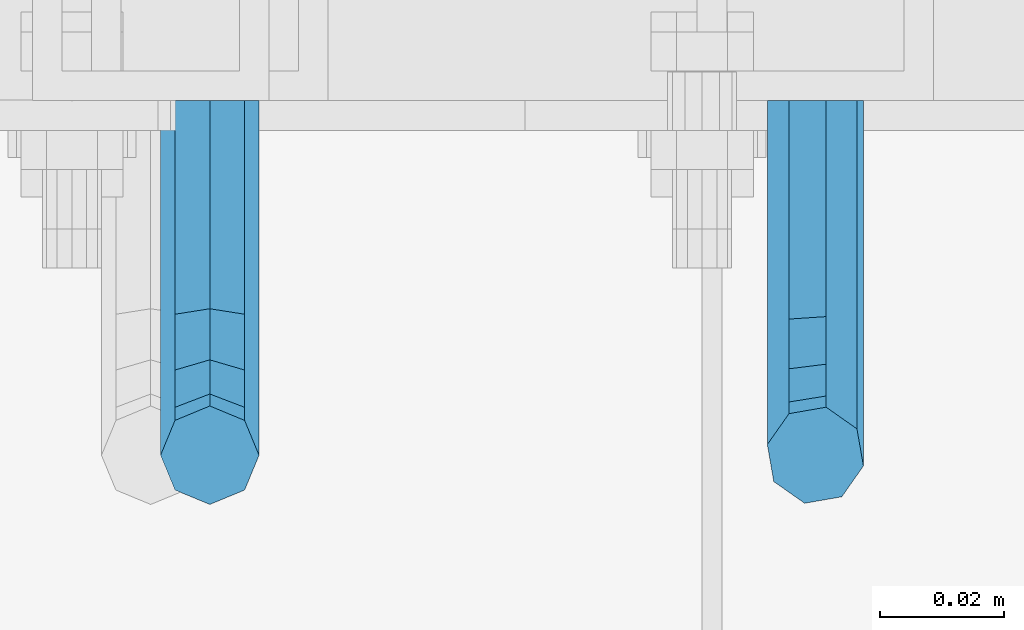
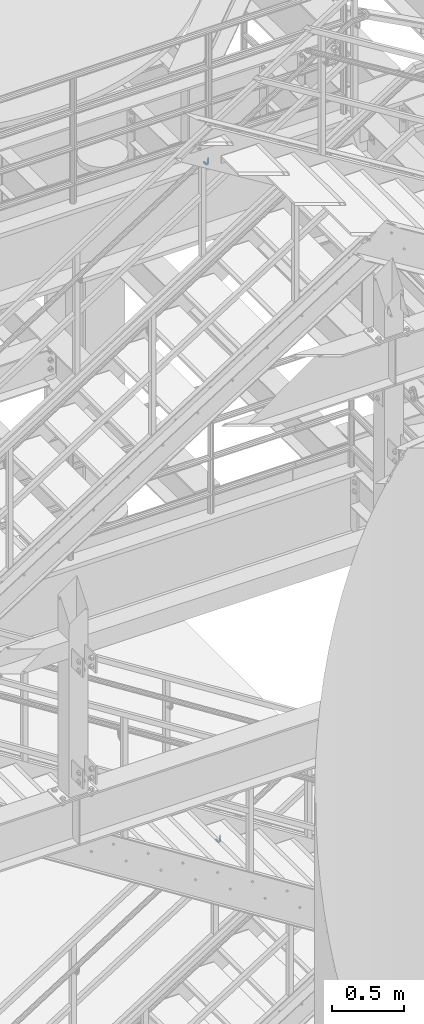
# One storey, part 1192 of 1876: 2 beams, 2 elements without a shape of their own.
"""IFC2X3 building model written with IfcOpenShell, lengths in millimetres."""

from ifc_helpers import new_model, si_unit, frame, origin_with_axes, place, context, subcontext, project, spatial, faceted_brep, material, type_object, element, aggregate, save


model = new_model("IFC2X3")

# Units and contexts
model_context = context("Model", 3, precision=1e-05, world=origin_with_axes())
body_context = subcontext(model_context, "Body", "Model", "MODEL_VIEW")
ifc_project = project(units=[si_unit("LENGTHUNIT", "METRE", prefix="MILLI"), si_unit("AREAUNIT", "SQUARE_METRE"), si_unit("VOLUMEUNIT", "CUBIC_METRE"), si_unit("MASSUNIT", "GRAM", prefix="KILO"), si_unit("TIMEUNIT", "SECOND"), si_unit("PLANEANGLEUNIT", "RADIAN"), si_unit("SOLIDANGLEUNIT", "STERADIAN"), si_unit("THERMODYNAMICTEMPERATUREUNIT", "DEGREE_CELSIUS"), si_unit("LUMINOUSINTENSITYUNIT", "LUMEN")], contexts=[model_context])

# Site, building, storey
site_placement = place(None, origin_with_axes())
site = spatial("IfcSite", under=ifc_project, at=site_placement, CompositionType="ELEMENT")
building_placement = place(site_placement, origin_with_axes())
building = spatial("IfcBuilding", under=site, at=building_placement, Name="Undefined", CompositionType="ELEMENT")
storey_placement = place(building_placement, origin_with_axes())
storey = spatial("IfcBuildingStorey", under=building, at=storey_placement, Name="Undefined", CompositionType="ELEMENT", Elevation=0.0)

# Assembly, beam
assembly_1_placement = place(storey_placement, origin_with_axes())
assembly_1 = element("IfcElementAssembly", 1, at=assembly_1_placement, inside=storey, Name="RAIL", AssemblyPlace="NOTDEFINED", PredefinedType="RIGID_FRAME")
ifc_material = material(Name="STEEL/A36")
beam_type = type_object("IfcBeamType", PredefinedType="NOTDEFINED")
beam_1_placement = place(assembly_1_placement, frame((4927.59999403856, -4800.59999885446, 8244.89769542987), z_axis=(1.0, 0.0, 0.0), x_axis=(0.0, -1.0, 0.0)))
beam_1 = element("IfcBeam", 2, at=beam_1_placement, type_object=beam_type, material=ifc_material, Name="BRACKET", context=body_context, shape_type="Brep", body=[
    faceted_brep([(0.0, -5.61266007566822, 5.61266007566883), (0.0, 0.0, 7.9375), (0.0, 5.61266007566822, 5.61266007566883), (0.0, 7.9375, 0.0), (0.0, 5.61266007566822, -5.61266007566883), (0.0, 0.0, -7.9375), (0.0, -5.61266007566822, -5.61266007566883), (0.0, -7.9375, 0.0), (23.8125, 5.61266007566883, 5.61266007566792), (23.8125, 7.9375, 0.0), (23.8125, 5.61266007566883, -5.61266007566792), (23.8125, 0.0, -7.9375), (23.8125, -5.61266007566883, -5.61266007566792), (23.8125, -7.9375, 0.0), (23.8125, -5.61266007566883, 5.61266007566792), (23.8125, 0.0, 7.9375), (36.5702095103989, -2.53766620105534, 7.9375), (38.7180815328547, 2.64775556579752, 5.61266007566792), (39.6077592547972, 4.79562758825296, 0.0), (38.7180815328547, 2.64775556579752, -5.61266007566792), (36.5702095103989, -2.53766620105534, -7.9375), (34.4223374879439, -7.72308796790867, -5.61266007566792), (33.5326597660014, -9.87095999036364, 0.0), (34.4223374879439, -7.72308796790867, 5.61266007566792), (43.4169233967659, -13.733078129113, 5.61266007566792), (47.385673396765, -9.76432812911298, 7.9375), (41.7730133210971, -15.3769882047809, 0.0), (43.4169233967659, -13.733078129113, -5.61266007566792), (47.385673396765, -9.76432812911298, -7.9375), (51.354423396765, -5.79557812911253, -5.61266007566792), (52.9983334724338, -4.15166805344461, 0.0), (51.354423396765, -5.79557812911253, 5.61266007566792), (54.6123353248231, -20.5797920154787, 7.9375), (59.7977570916764, -18.4319199930233, 5.61266007566792), (49.4269135579698, -22.7276640379341, 5.61266007566792), (47.2790415355148, -23.6173417598766, 0.0), (49.4269135579698, -22.7276640379341, -5.61266007566792), (54.6123353248231, -20.5797920154787, -7.9375), (59.7977570916764, -18.4319199930233, -5.61266007566792), (61.9456291141314, -17.5422422710808, 0.0), (62.7626616015468, -33.3375015258789, 5.61266007566792), (65.0875015258789, -33.3375015258789, 0.0), (57.1500015258789, -33.3375015258789, 7.9375), (51.5373414502101, -33.3375015258789, 5.61266007566792), (49.2125015258789, -33.3375015258789, 0.0), (51.5373414502101, -33.3375015258789, -5.61266007566792), (57.1500015258789, -33.3375015258789, -7.9375), (62.7626616015468, -33.3375015258789, -5.61266007566792), (65.0875015258789, -66.3198535804604, 0.0), (62.7626616015468, -62.7481608643047, -5.61266007566792), (57.1500015258789, -61.2687173006434, -7.9375), (51.537341450211, -62.7481608643047, -5.61266007566792), (49.2125015258789, -66.3198535804604, 0.0), (51.537341450211, -69.8915462966161, 5.61266007566792), (57.1500015258789, -71.3709898602756, 7.9375), (62.7626616015468, -69.8915462966161, 5.61266007566792)], [[[0, 1, 2, 3, 4, 5, 6, 7]], [[3, 2, 8, 9]], [[4, 3, 9, 10]], [[5, 4, 10, 11]], [[6, 5, 11, 12]], [[7, 6, 12, 13]], [[0, 7, 13, 14]], [[1, 0, 14, 15]], [[2, 1, 15, 8]], [[8, 15, 16, 17]], [[9, 8, 17, 18]], [[10, 9, 18, 19]], [[11, 10, 19, 20]], [[12, 11, 20, 21]], [[13, 12, 21, 22]], [[14, 13, 22, 23]], [[15, 14, 23, 16]], [[23, 24, 25, 16]], [[22, 26, 24, 23]], [[21, 27, 26, 22]], [[20, 28, 27, 21]], [[19, 29, 28, 20]], [[18, 30, 29, 19]], [[17, 31, 30, 18]], [[16, 25, 31, 17]], [[25, 32, 33, 31]], [[24, 34, 32, 25]], [[26, 35, 34, 24]], [[27, 36, 35, 26]], [[28, 37, 36, 27]], [[29, 38, 37, 28]], [[30, 39, 38, 29]], [[31, 33, 39, 30]], [[33, 40, 41, 39]], [[32, 42, 40, 33]], [[34, 43, 42, 32]], [[35, 44, 43, 34]], [[36, 45, 44, 35]], [[37, 46, 45, 36]], [[38, 47, 46, 37]], [[39, 41, 47, 38]], [[47, 41, 48, 49]], [[46, 47, 49, 50]], [[45, 46, 50, 51]], [[44, 45, 51, 52]], [[43, 44, 52, 53]], [[42, 43, 53, 54]], [[40, 42, 54, 55]], [[41, 40, 55, 48]], [[54, 53, 52, 51, 50, 49, 48, 55]]]),
])
aggregate(assembly_1, [beam_1])

assembly_2_placement = place(storey_placement, origin_with_axes())
assembly_2 = element("IfcElementAssembly", 3, at=assembly_2_placement, inside=storey, Name="RAIL", AssemblyPlace="NOTDEFINED", PredefinedType="RIGID_FRAME")
beam_2_placement = place(assembly_2_placement, frame((5025.2312500129, -4800.59999885446, 2450.48329232834), z_axis=(0.844410015326383, 0.0, 0.535697420207059), x_axis=(0.0, -1.0, 0.0)))
beam_2 = element("IfcBeam", 4, at=beam_2_placement, type_object=beam_type, material=ifc_material, Name="BRACKET", context=body_context, shape_type="Brep", body=[
    faceted_brep([(0.0, -5.61266007566822, 5.61266007566883), (0.0, 0.0, 7.9375), (0.0, 5.61266007566822, 5.61266007566883), (0.0, 7.9375, 0.0), (0.0, 5.61266007566822, -5.61266007566883), (0.0, 0.0, -7.9375), (0.0, -5.61266007566822, -5.61266007566883), (0.0, -7.9375, 0.0), (25.7500019073486, 7.93750000000102, 9.09494701772928e-13), (25.7500019073486, 5.61266007566837, -5.61266007566837), (25.7500019073486, -6.82121026329696e-13, -7.93750000000091), (25.7500019073486, -5.6126600756694, -5.61266007566974), (25.7500019073486, -7.93750000000102, -1.81898940354586e-12), (25.7500019073486, -5.61266007566837, 5.61266007566746), (25.7500019073486, 6.82121026329696e-13, 7.93750000000045), (25.7500019073486, 5.6126600756694, 5.61266007566928), (38.4293366836664, 3.48299342205155, 6.96372994876174), (40.3311989638523, 5.48838972025123, 1.55372631168893), (40.7305556863994, 3.09647240503659, -4.01637957277262), (39.3934690994565, -2.29160580041184, -6.48369522136136), (37.103186391596, -7.51958175847221, -4.40290058978781), (35.20132411141, -9.5249780566719, 1.00710304728545), (34.8019673888657, -7.13306074145851, 6.57720893174746), (36.1390539758049, -1.74498253600871, 9.04452458033529), (44.9464670438292, -6.71427237123442, 12.1970638641865), (49.1783576787429, -2.58178409626339, 10.8112514273389), (42.4758531820917, -11.4627955199268, 9.32401168030583), (43.2137681863505, -14.0457330830792, 3.87508987960746), (46.7279514549882, -12.95003526696, -0.957797047369695), (50.9598420899019, -8.81754699198905, -2.34360948421772), (53.4304559516395, -4.06902384329646, 0.529442699663377), (52.6925409473806, -1.48608628014392, 5.97836450036175), (56.3606238862012, -11.6583650794599, 16.5694742441578), (60.952125596792, -11.9241272539106, 12.6003035112408), (50.8313923112155, -14.1513401749901, 16.9151723234295), (47.6033797389591, -17.942701540198, 13.4348925027043), (48.5675121547501, -20.8115211072019, 8.16733550011031), (53.159013865341, -21.0772832816523, 4.19816476719325), (58.6882454403267, -18.5843081861219, 3.85246668792206), (61.916258012584, -14.7929468209162, 7.33274650864814), (63.8525060225302, -24.2366360838653, 20.4114131579445), (64.8960754294303, -27.4426764670732, 15.3577905213597), (58.8827003833576, -22.3649223522546, 23.3617611737764), (52.8979032529824, -22.9239597913389, 22.4805607149005), (49.4039276223266, -25.5862718511769, 18.2840070589591), (50.4474970292276, -28.7923122343848, 13.2303844223738), (55.4173026683993, -30.6640259659952, 10.2800364065429), (61.4020997987745, -30.104988526911, 11.1612368654173), (64.8960754294312, -56.018050113816, 33.4861329926521), (61.4020997987755, -56.0180500190148, 27.6005968197555), (55.4173026684002, -56.018049999108, 26.364740543037), (50.4474970292276, -56.0180500657575, 30.5025120082541), (49.4039276223266, -56.01805017992, 37.5900608090838), (52.8979032529824, -56.0180502747214, 43.4755969819798), (58.8827003833576, -56.018050294628, 44.7114532586984), (63.8525060225302, -56.018050227979, 40.5736817934817)], [[[0, 1, 2, 3, 4, 5, 6, 7]], [[4, 3, 8, 9]], [[5, 4, 9, 10]], [[6, 5, 10, 11]], [[7, 6, 11, 12]], [[0, 7, 12, 13]], [[1, 0, 13, 14]], [[2, 1, 14, 15]], [[3, 2, 15, 8]], [[8, 15, 16, 17]], [[9, 8, 17, 18]], [[10, 9, 18, 19]], [[11, 10, 19, 20]], [[12, 11, 20, 21]], [[13, 12, 21, 22]], [[14, 13, 22, 23]], [[15, 14, 23, 16]], [[23, 24, 25, 16]], [[22, 26, 24, 23]], [[21, 27, 26, 22]], [[20, 28, 27, 21]], [[19, 29, 28, 20]], [[18, 30, 29, 19]], [[17, 31, 30, 18]], [[16, 25, 31, 17]], [[25, 32, 33, 31]], [[24, 34, 32, 25]], [[26, 35, 34, 24]], [[27, 36, 35, 26]], [[28, 37, 36, 27]], [[29, 38, 37, 28]], [[30, 39, 38, 29]], [[31, 33, 39, 30]], [[33, 40, 41, 39]], [[32, 42, 40, 33]], [[34, 43, 42, 32]], [[35, 44, 43, 34]], [[36, 45, 44, 35]], [[37, 46, 45, 36]], [[38, 47, 46, 37]], [[39, 41, 47, 38]], [[47, 41, 48, 49]], [[46, 47, 49, 50]], [[45, 46, 50, 51]], [[44, 45, 51, 52]], [[43, 44, 52, 53]], [[42, 43, 53, 54]], [[40, 42, 54, 55]], [[41, 40, 55, 48]], [[54, 53, 52, 51, 50, 49, 48, 55]]]),
])
aggregate(assembly_2, [beam_2])

save(model, "model.ifc")
